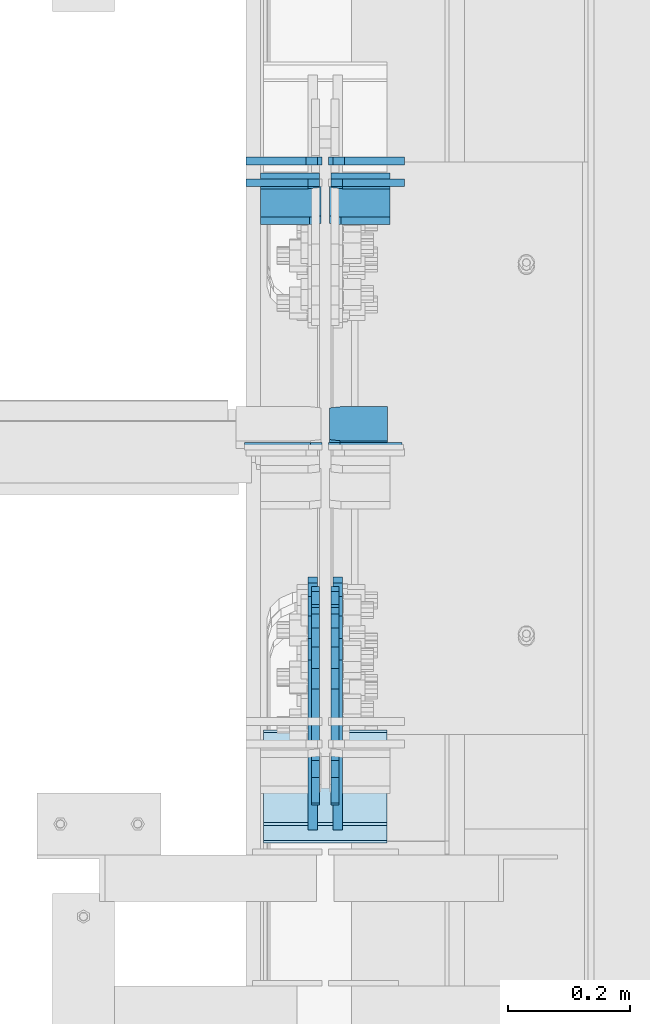
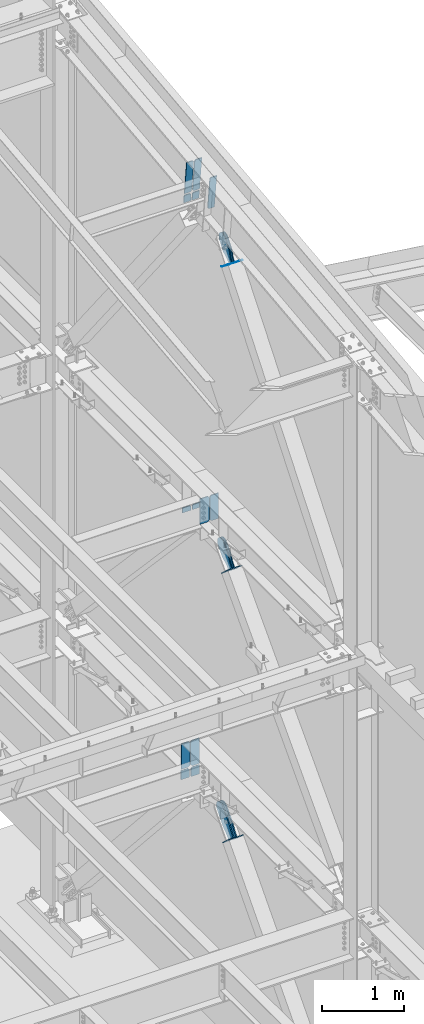
# One storey, part 1048 of 1179: 22 plates, 12 elements without a shape of their own.
"""IFC2X3 building model written with IfcOpenShell, lengths in millimetres."""

from ifc_helpers import new_model, si_unit, frame, origin_with_axes, place, context, subcontext, project, spatial, faceted_brep, material, type_object, element, aggregate, save


model = new_model("IFC2X3")

# Units and contexts
model_context = context("Model", 3, precision=1e-05, world=origin_with_axes())
body_context = subcontext(model_context, "Body", "Model", "MODEL_VIEW")
ifc_project = project(units=[si_unit("LENGTHUNIT", "METRE", prefix="MILLI"), si_unit("AREAUNIT", "SQUARE_METRE"), si_unit("VOLUMEUNIT", "CUBIC_METRE"), si_unit("MASSUNIT", "GRAM", prefix="KILO"), si_unit("TIMEUNIT", "SECOND"), si_unit("PLANEANGLEUNIT", "RADIAN"), si_unit("SOLIDANGLEUNIT", "STERADIAN"), si_unit("THERMODYNAMICTEMPERATUREUNIT", "DEGREE_CELSIUS"), si_unit("LUMINOUSINTENSITYUNIT", "LUMEN")], contexts=[model_context])

# Site, building, storey
site_placement = place(None, origin_with_axes())
site = spatial("IfcSite", under=ifc_project, at=site_placement, CompositionType="ELEMENT")
building_placement = place(site_placement, origin_with_axes())
building = spatial("IfcBuilding", under=site, at=building_placement, Name="Undefined", CompositionType="ELEMENT")
storey_placement = place(building_placement, origin_with_axes())
storey = spatial("IfcBuildingStorey", under=building, at=storey_placement, Name="Undefined", CompositionType="ELEMENT", Elevation=0.0)

# Assembly, plates
assembly_1_placement = place(storey_placement, origin_with_axes())
assembly_1 = element("IfcElementAssembly", 1, at=assembly_1_placement, inside=storey, Name="BEAM", AssemblyPlace="NOTDEFINED", PredefinedType="RIGID_FRAME")
ifc_material_1 = material(Name="STEEL/A36")
plate_type_1 = type_object("IfcPlateType", PredefinedType="NOTDEFINED")
plate_1_placement = place(assembly_1_placement, frame((24314.94375, 30789.5969267613, 12198.8547612226), z_axis=(0.0, -0.112284087038017, 0.993676146336441), x_axis=(1.0, 0.0, 0.0)))
plate_1 = element("IfcPlate", 2, at=plate_1_placement, type_object=plate_type_1, material=ifc_material_1, Name="PLATE", context=body_context, shape_type="Brep", body=[
    faceted_brep([(0.0, -6.34999999998763, 17.4624996185248), (0.0, -6.34999999979846, 481.012500380079), (0.0, 6.350000000195, 481.012500380073), (0.0, 6.35000000000582, 17.4624996185175), (17.4624996185303, -6.349999999793, 498.474999998598), (17.4624996185303, 6.35000000020045, 498.474999998592), (95.25, -6.349999999793, 498.474999998598), (95.25, 6.35000000020045, 498.474999998592), (95.25, -6.34999999999309, 1.81898940354586e-12), (95.25, 6.34999999999854, -1.81898940354586e-12), (17.4624996185303, -6.34999999999309, 1.81898940354586e-12), (17.4624996185303, 6.34999999999854, -1.81898940354586e-12)], [[[0, 1, 2, 3]], [[1, 4, 5, 2]], [[4, 6, 7, 5]], [[6, 8, 9, 7]], [[8, 10, 11, 9]], [[10, 0, 3, 11]], [[5, 7, 9, 11, 3, 2]], [[10, 8, 6, 4, 1, 0]]]),
])
ifc_material_2 = material(Name="STEEL/A572-GR.50")
plate_type_2 = type_object("IfcPlateType", PredefinedType="NOTDEFINED")
plate_2_placement = place(assembly_1_placement, frame((24414.1625, 31157.0572320607, 12240.377288512), z_axis=(0.0, -0.112284087038017, 0.993676146336441), x_axis=(-1.0, 0.0, 0.0)))
plate_2 = element("IfcPlate", 3, at=plate_2_placement, type_object=plate_type_2, material=ifc_material_2, Name="PLATE", context=body_context, shape_type="Brep", body=[
    faceted_brep([(0.0, -6.34999999999854, 0.0), (0.0, -6.35000000019863, 498.474999998592), (0.0, 6.34999999979118, 498.474999998596), (0.0, 6.34999999999854, 0.0), (80.1687507629395, -6.35000000020227, 498.474999998592), (80.1687507629395, 6.34999999978754, 498.474999998596), (99.21875, -6.350000000195, 479.425000761543), (99.21875, 6.34999999980209, 479.425000761548), (99.21875, -6.35000000000946, 19.0499992370478), (99.21875, 6.34999999998399, 19.0499992370533), (80.1687507629395, -6.35000000000218, 0.0), (80.1687507629395, 6.34999999999491, 3.63797880709171e-12)], [[[0, 1, 2, 3]], [[1, 4, 5, 2]], [[4, 6, 7, 5]], [[6, 8, 9, 7]], [[8, 10, 11, 9]], [[10, 0, 3, 11]], [[5, 7, 9, 11, 3, 2]], [[10, 8, 6, 4, 1, 0]]]),
])
plate_3_placement = place(assembly_1_placement, frame((24300.65625, 31157.0572320607, 12240.377288512), z_axis=(0.0, -0.112284087038017, 0.993676146336441), x_axis=(-1.0, 0.0, 0.0)))
plate_3 = element("IfcPlate", 4, at=plate_3_placement, type_object=plate_type_2, material=ifc_material_2, Name="PLATE", context=body_context, shape_type="Brep", body=[
    faceted_brep([(0.0, -6.35000000000036, 19.0499999999993), (0.0, -6.350000000195, 479.425000761541), (0.0, 6.34999999980209, 479.425000761548), (0.0, 6.35000000000036, 19.0499999999993), (19.0499992370605, -6.35000000019863, 498.474999998592), (19.0499992370605, 6.34999999979118, 498.474999998596), (99.21875, -6.35000000020227, 498.474999998592), (99.21875, 6.34999999978754, 498.474999998596), (99.21875, -6.35000000000218, 0.0), (99.21875, 6.34999999999491, 3.63797880709171e-12), (19.0500000000002, -6.35000000000036, 0.0), (19.0500000000002, 6.35000000000036, 0.0)], [[[0, 1, 2, 3]], [[1, 4, 5, 2]], [[4, 6, 7, 5]], [[6, 8, 9, 7]], [[8, 10, 11, 9]], [[3, 11, 10, 0]], [[5, 7, 9, 11, 3, 2]], [[10, 8, 6, 4, 1, 0]]]),
])

# Assembly, plate
assembly_2_placement = place(storey_placement, origin_with_axes())
assembly_2 = element("IfcElementAssembly", 5, at=assembly_2_placement, inside=storey, Name="BEAM", AssemblyPlace="NOTDEFINED", PredefinedType="RIGID_FRAME")
plate_type_3 = type_object("IfcPlateType", PredefinedType="NOTDEFINED")
plate_4_placement = place(assembly_2_placement, frame((24313.35625, 31199.2949954247, 3703.6375), z_axis=(0.0, 0.0, 1.0), x_axis=(1.0, 0.0, 0.0)))
plate_4 = element("IfcPlate", 6, at=plate_4_placement, type_object=plate_type_3, material=ifc_material_2, Name="PLATE", context=body_context, shape_type="Brep", body=[
    faceted_brep([(0.0, -6.34999999999854, 22.2250003814697), (0.0, -6.34999999999854, 355.600011825562), (0.0, 6.34999999999854, 355.600011825562), (0.0, 6.34999999999854, 22.2250003814697), (22.2250003814697, -6.34999999999854, 377.825012207031), (22.2250003814697, 6.34999999999854, 377.825012207031), (120.650001525879, -6.34999999999854, 377.825012207031), (120.650001525879, 6.34999999999854, 377.825012207031), (120.650001525879, -6.34999999999854, 0.0), (120.650001525879, 6.34999999999854, 0.0), (22.2250003814697, -6.34999999999854, 0.0), (22.2250003814697, 6.34999999999854, 0.0)], [[[0, 1, 2, 3]], [[1, 4, 5, 2]], [[4, 6, 7, 5]], [[6, 8, 9, 7]], [[8, 10, 11, 9]], [[10, 0, 3, 11]], [[5, 7, 9, 11, 3, 2]], [[10, 8, 6, 4, 1, 0]]]),
])

assembly_3_placement = place(storey_placement, origin_with_axes())
assembly_3 = element("IfcElementAssembly", 7, at=assembly_3_placement, inside=storey, Name="BEAM", AssemblyPlace="NOTDEFINED", PredefinedType="RIGID_FRAME")
plate_5_placement = place(assembly_3_placement, frame((24313.35625, 30730.825, 7615.2375), z_axis=(0.0, 0.0, 1.0), x_axis=(1.0, 0.0, 0.0)))
plate_5 = element("IfcPlate", 8, at=plate_5_placement, type_object=plate_type_3, material=ifc_material_2, Name="PLATE", context=body_context, shape_type="Brep", body=[
    faceted_brep([(0.0, -6.35000000000036, 19.0499999999993), (0.0, -6.34999999999854, 358.775000762939), (0.0, 6.34999999999854, 358.775000762939), (0.0, 6.35000000000036, 19.0499999999993), (19.0499992370605, -6.34999999999854, 377.825), (19.0499992370605, 6.34999999999854, 377.825), (120.650001525879, -6.34999999999854, 377.825012207031), (120.650001525879, 6.34999999999854, 377.825012207031), (120.650001525879, -6.34999999999854, 0.0), (120.650001525879, 6.34999999999854, 0.0), (19.0500000000002, -6.35000000000036, 0.0), (19.0500000000002, 6.35000000000036, 0.0)], [[[0, 1, 2, 3]], [[1, 4, 5, 2]], [[4, 6, 7, 5]], [[6, 8, 9, 7]], [[8, 10, 11, 9]], [[3, 11, 10, 0]], [[5, 7, 9, 11, 3, 2]], [[10, 8, 6, 4, 1, 0]]]),
])

# Plate
plate_6_placement = place(assembly_2_placement, frame((24302.24375, 31199.2949954247, 3703.6375), z_axis=(0.0, 0.0, 1.0), x_axis=(-1.0, 0.0, 0.0)))
plate_6 = element("IfcPlate", 9, at=plate_6_placement, type_object=plate_type_3, material=ifc_material_2, Name="PLATE", context=body_context, shape_type="Brep", body=[
    faceted_brep([(0.0, -6.34999999999854, 22.2250003814697), (0.0, -6.34999999999854, 355.600011825562), (0.0, 6.34999999999854, 355.600011825562), (0.0, 6.34999999999854, 22.2250003814697), (22.2250003814697, -6.34999999999854, 377.825012207031), (22.2250003814697, 6.34999999999854, 377.825012207031), (120.650001525879, -6.34999999999854, 377.825012207031), (120.650001525879, 6.34999999999854, 377.825012207031), (120.650001525879, -6.34999999999854, 0.0), (120.650001525879, 6.34999999999854, 0.0), (22.2250003814697, -6.34999999999854, 0.0), (22.2250003814697, 6.34999999999854, 0.0)], [[[0, 1, 2, 3]], [[1, 4, 5, 2]], [[4, 6, 7, 5]], [[6, 8, 9, 7]], [[8, 10, 11, 9]], [[10, 0, 3, 11]], [[5, 7, 9, 11, 3, 2]], [[10, 8, 6, 4, 1, 0]]]),
])

# Assembly, plate
assembly_4_placement = place(storey_placement, origin_with_axes())
assembly_4 = element("IfcElementAssembly", 10, at=assembly_4_placement, inside=storey, AssemblyPlace="NOTDEFINED", PredefinedType="RIGID_FRAME")
plate_type_4 = type_object("IfcPlateType", PredefinedType="NOTDEFINED")
plate_7_placement = place(assembly_4_placement, frame((24291.925, 30217.3266716375, 11731.3433869439), z_axis=(0.0, -0.784153429306141, 0.620566998242268), x_axis=(0.0, 0.62056699824227, 0.78415342930614)))
plate_7 = element("IfcPlate", 11, at=plate_7_placement, type_object=plate_type_4, material=ifc_material_1, context=body_context, shape_type="Brep", body=[
    faceted_brep([(0.0, -6.34999999999854, 0.0), (-8.18545231595635e-11, -6.34999999999854, 91.5986124346418), (-8.18545231595635e-11, 6.34999999999854, 91.5986124346418), (0.0, 6.34999999999854, 0.0), (67.3100000000013, -6.35000000000002, 91.5986124352912), (67.3100000000013, 6.35000000000002, 91.5986124352912), (168.909999999782, -6.35000000000002, 136.286806218), (168.909999999782, 6.35000000000002, 136.286806218), (313.994985846162, -6.35000000000002, 136.286806217971), (313.994985846162, 6.35000000000002, 136.286806217971), (348.623054100175, -6.35000000000002, 129.398855183776), (348.623054100175, 6.35000000000002, 129.398855183776), (377.979312866712, -6.35000000000002, 109.783630186734), (377.979312866712, 6.35000000000002, 109.783630186734), (397.594537863708, -6.35000000000002, 80.4273714201881), (397.594537863708, 6.35000000000002, 80.4273714201881), (404.482488897822, -6.35000000000002, 45.7993092687429), (404.482488897822, 6.35000000000002, 45.7993092687429), (397.594537863562, -6.35000000000002, 11.1712410148175), (397.594537863562, 6.35000000000002, 11.1712410148175), (377.979312866471, -6.35000000000002, -18.1850177516571), (377.979312866471, 6.35000000000002, -18.1850177516571), (348.623054099906, -6.35000000000002, -37.800242748639), (348.623054099906, 6.35000000000002, -37.800242748639), (313.994988897899, -6.35000000000002, -44.6881937828002), (313.994988897899, 6.35000000000002, -44.6881937828002), (168.909999999352, -6.35000000000002, -44.6881937827711), (168.909999999352, 6.35000000000002, -44.6881937827711), (67.309999999783, -6.35000000000002, -1.09139364212751e-11), (67.309999999783, 6.35000000000002, -1.09139364212751e-11)], [[[0, 1, 2, 3]], [[1, 4, 5, 2]], [[4, 6, 7, 5]], [[6, 8, 9, 7]], [[8, 10, 11, 9]], [[10, 12, 13, 11]], [[12, 14, 15, 13]], [[14, 16, 17, 15]], [[16, 18, 19, 17]], [[18, 20, 21, 19]], [[20, 22, 23, 21]], [[22, 24, 25, 23]], [[24, 26, 27, 25]], [[26, 28, 29, 27]], [[28, 0, 3, 29]], [[5, 7, 9, 11, 13, 15, 17, 19, 21, 23, 25, 27, 29, 3, 2]], [[28, 26, 24, 22, 20, 18, 16, 14, 12, 10, 8, 6, 4, 1, 0]]]),
])
aggregate(assembly_4, [plate_7])

assembly_5_placement = place(storey_placement, origin_with_axes())
assembly_5 = element("IfcElementAssembly", 12, at=assembly_5_placement, inside=storey, AssemblyPlace="NOTDEFINED", PredefinedType="RIGID_FRAME")
plate_8_placement = place(assembly_5_placement, frame((24323.675, 30217.3266716375, 11731.3433869439), z_axis=(0.0, -0.784153429306141, 0.620566998242268), x_axis=(0.0, 0.62056699824227, 0.78415342930614)))
plate_8 = element("IfcPlate", 13, at=plate_8_placement, type_object=plate_type_4, material=ifc_material_1, context=body_context, shape_type="Brep", body=[
    faceted_brep([(0.0, -6.34999999999854, 0.0), (-8.18545231595635e-11, -6.34999999999854, 91.5986124346418), (-8.18545231595635e-11, 6.34999999999854, 91.5986124346418), (0.0, 6.34999999999854, 0.0), (67.3100000000013, -6.35000000000002, 91.5986124352912), (67.3100000000013, 6.35000000000002, 91.5986124352912), (168.909999999782, -6.35000000000002, 136.286806218), (168.909999999782, 6.35000000000002, 136.286806218), (313.994985846162, -6.35000000000002, 136.286806217971), (313.994985846162, 6.35000000000002, 136.286806217971), (348.623054100175, -6.35000000000002, 129.398855183776), (348.623054100175, 6.35000000000002, 129.398855183776), (377.979312866712, -6.35000000000002, 109.783630186734), (377.979312866712, 6.35000000000002, 109.783630186734), (397.594537863708, -6.35000000000002, 80.4273714201881), (397.594537863708, 6.35000000000002, 80.4273714201881), (404.482488897822, -6.35000000000002, 45.7993092687429), (404.482488897822, 6.35000000000002, 45.7993092687429), (397.594537863562, -6.35000000000002, 11.1712410148175), (397.594537863562, 6.35000000000002, 11.1712410148175), (377.979312866471, -6.35000000000002, -18.1850177516571), (377.979312866471, 6.35000000000002, -18.1850177516571), (348.623054099906, -6.35000000000002, -37.800242748639), (348.623054099906, 6.35000000000002, -37.800242748639), (313.994988897899, -6.35000000000002, -44.6881937828002), (313.994988897899, 6.35000000000002, -44.6881937828002), (168.909999999352, -6.35000000000002, -44.6881937827711), (168.909999999352, 6.35000000000002, -44.6881937827711), (67.309999999783, -6.35000000000002, -1.09139364212751e-11), (67.309999999783, 6.35000000000002, -1.09139364212751e-11)], [[[0, 1, 2, 3]], [[1, 4, 5, 2]], [[4, 6, 7, 5]], [[6, 8, 9, 7]], [[8, 10, 11, 9]], [[10, 12, 13, 11]], [[12, 14, 15, 13]], [[14, 16, 17, 15]], [[16, 18, 19, 17]], [[18, 20, 21, 19]], [[20, 22, 23, 21]], [[22, 24, 25, 23]], [[24, 26, 27, 25]], [[26, 28, 29, 27]], [[28, 0, 3, 29]], [[5, 7, 9, 11, 13, 15, 17, 19, 21, 23, 25, 27, 29, 3, 2]], [[28, 26, 24, 22, 20, 18, 16, 14, 12, 10, 8, 6, 4, 1, 0]]]),
])
aggregate(assembly_5, [plate_8])

assembly_6_placement = place(storey_placement, origin_with_axes())
assembly_6 = element("IfcElementAssembly", 14, at=assembly_6_placement, inside=storey, Name="Plate", AssemblyPlace="NOTDEFINED", PredefinedType="RIGID_FRAME")
plate_type_5 = type_object("IfcPlateType", PredefinedType="NOTDEFINED")
plate_9_placement = place(assembly_6_placement, frame((24409.4, 30263.0532772467, 11699.2050050436), z_axis=(0.0, -0.784153429306141, 0.620566998242268), x_axis=(-1.0, 0.0, 0.0)))
plate_9 = element("IfcPlate", 15, at=plate_9_placement, type_object=plate_type_5, material=ifc_material_1, Name="Plate", context=body_context, shape_type="Brep", body=[
    faceted_brep([(0.0, -3.17500000000109, 0.0), (0.0, -3.17500000000291, 203.200000000368), (0.0, 3.17499999998836, 203.200000000361), (0.0, 3.17500000000109, 7.27595761418343e-12), (203.199999999997, -3.17500000000291, 203.200000000368), (203.199999999997, 3.17499999998836, 203.200000000361), (203.199999999997, -3.17499999999927, 3.63797880709171e-12), (203.199999999997, 3.17499999999382, -3.63797880709171e-12)], [[[0, 1, 2, 3]], [[1, 4, 5, 2]], [[4, 6, 7, 5]], [[6, 0, 3, 7]], [[5, 7, 3, 2]], [[6, 4, 1, 0]]]),
])
aggregate(assembly_6, [plate_9])

assembly_7_placement = place(storey_placement, origin_with_axes())
assembly_7 = element("IfcElementAssembly", 16, at=assembly_7_placement, inside=storey, Name="Plate", AssemblyPlace="NOTDEFINED", PredefinedType="RIGID_FRAME")
plate_10_placement = place(assembly_7_placement, frame((24409.4, 30258.8835102987, 7162.85000800912), z_axis=(0.0, -0.729241792887682, 0.684256097894611), x_axis=(-1.0, 0.0, 0.0)))
plate_10 = element("IfcPlate", 17, at=plate_10_placement, type_object=plate_type_5, material=ifc_material_1, Name="Plate", context=body_context, shape_type="Brep", body=[
    faceted_brep([(0.0, -3.17500000000109, 0.0), (0.0, -3.17500000000291, 203.200000000368), (0.0, 3.17499999998836, 203.200000000361), (0.0, 3.17500000000109, 7.27595761418343e-12), (203.199999999997, -3.17500000000291, 203.200000000368), (203.199999999997, 3.17499999998836, 203.200000000361), (203.199999999997, -3.17499999999927, 3.63797880709171e-12), (203.199999999997, 3.17499999999382, -3.63797880709171e-12)], [[[0, 1, 2, 3]], [[1, 4, 5, 2]], [[4, 6, 7, 5]], [[6, 0, 3, 7]], [[5, 7, 3, 2]], [[6, 4, 1, 0]]]),
])
aggregate(assembly_7, [plate_10])

assembly_8_placement = place(storey_placement, origin_with_axes())
assembly_8 = element("IfcElementAssembly", 18, at=assembly_8_placement, inside=storey, Name="Plate", AssemblyPlace="NOTDEFINED", PredefinedType="RIGID_FRAME")
plate_11_placement = place(assembly_8_placement, frame((24409.4, 30233.4403584389, 3193.9493141799), z_axis=(0.0, -0.74575357167811, 0.666221892712438), x_axis=(-1.0, 0.0, 0.0)))
plate_11 = element("IfcPlate", 19, at=plate_11_placement, type_object=plate_type_5, material=ifc_material_1, Name="Plate", context=body_context, shape_type="Brep", body=[
    faceted_brep([(0.0, -3.17500000000109, 0.0), (0.0, -3.17500000000291, 203.200000000368), (0.0, 3.17499999998836, 203.200000000361), (0.0, 3.17500000000109, 7.27595761418343e-12), (203.199999999997, -3.17500000000291, 203.200000000368), (203.199999999997, 3.17499999998836, 203.200000000361), (203.199999999997, -3.17499999999927, 3.63797880709171e-12), (203.199999999997, 3.17499999999382, -3.63797880709171e-12)], [[[0, 1, 2, 3]], [[1, 4, 5, 2]], [[4, 6, 7, 5]], [[6, 0, 3, 7]], [[5, 7, 3, 2]], [[6, 4, 1, 0]]]),
])
aggregate(assembly_8, [plate_11])

# Plate
plate_type_6 = type_object("IfcPlateType", PredefinedType="NOTDEFINED")
plate_12_placement = place(assembly_1_placement, frame((24298.275, 31159.909247798, 12215.1379150462), z_axis=(-1.0, 0.0, 0.0), x_axis=(0.0, 0.112284087038014, -0.993676146336441)))
plate_12 = element("IfcPlate", 20, at=plate_12_placement, type_object=plate_type_6, material=ifc_material_2, Name="PLATE", context=body_context, shape_type="Brep", body=[
    faceted_brep([(0.0, 6.35000000000036, 19.0499999999993), (19.0500000000002, 6.35000000000036, 0.0), (19.0500000000002, -6.35000000000036, 0.0), (0.0, -6.35000000000036, 19.0499999999993), (0.0, -6.35000000000036, 96.8374999999978), (0.0, 6.35000000000036, 96.8374999999978), (118.580622349293, -6.34999999995489, 96.8374999999978), (118.580622349285, 6.35000000003856, 96.8374999999978), (118.580622349293, -6.34999999995489, 0.0), (118.580622349285, 6.35000000003856, 0.0)], [[[0, 1, 2, 3]], [[4, 5, 0, 3]], [[4, 6, 7, 5]], [[6, 8, 9, 7]], [[9, 8, 2, 1]], [[5, 7, 9, 1, 0]], [[8, 6, 4, 3, 2]]]),
])

plate_13_placement = place(assembly_1_placement, frame((24317.325, 31159.909247798, 12215.1379150462), z_axis=(1.0, 0.0, 0.0), x_axis=(0.0, 0.112284087038014, -0.993676146336441)))
plate_13 = element("IfcPlate", 21, at=plate_13_placement, type_object=plate_type_6, material=ifc_material_2, Name="PLATE", context=body_context, shape_type="Brep", body=[
    faceted_brep([(0.0, 6.35000000000036, 19.0499999999993), (19.0500000000002, 6.35000000000036, 0.0), (19.0500000000002, -6.35000000000036, 0.0), (0.0, -6.35000000000036, 19.0499999999993), (0.0, -6.35000000000036, 96.8374999999978), (0.0, 6.35000000000036, 96.8374999999978), (118.580622349293, -6.34999999995489, 96.8374999999978), (118.580622349285, 6.35000000003856, 96.8374999999978), (118.580622349293, -6.34999999995489, 0.0), (118.580622349285, 6.35000000003856, 0.0)], [[[0, 1, 2, 3]], [[4, 5, 0, 3]], [[4, 6, 7, 5]], [[6, 8, 9, 7]], [[9, 8, 2, 1]], [[5, 7, 9, 1, 0]], [[8, 6, 4, 3, 2]]]),
])

aggregate(assembly_1, [plate_1, plate_2, plate_3, plate_12, plate_13])

plate_type_7 = type_object("IfcPlateType", PredefinedType="NOTDEFINED")
plate_14_placement = place(assembly_3_placement, frame((24302.24375, 30730.825, 7615.2375), z_axis=(0.0, 0.0, 1.0), x_axis=(-1.0, 0.0, 0.0)))
plate_14 = element("IfcPlate", 22, at=plate_14_placement, type_object=plate_type_7, material=ifc_material_2, Name="PLATE", context=body_context, shape_type="Brep", body=[
    faceted_brep([(0.0, -6.35000000000036, 19.0499999999993), (0.0, -6.34999999999854, 358.775000762939), (0.0, 6.34999999999854, 358.775000762939), (0.0, 6.35000000000036, 19.0499999999993), (19.0499992370605, -6.34999999999854, 377.825), (19.0499992370605, 6.34999999999854, 377.825), (127.000004873051, -6.34999999999854, 377.825), (127.000004873051, 6.34999999999854, 377.825), (127.000004873051, -6.34999999999854, 0.0), (127.000004873051, 6.34999999999854, 0.0), (19.0500000000002, -6.35000000000036, 0.0), (19.0500000000002, 6.35000000000036, 0.0)], [[[0, 1, 2, 3]], [[1, 4, 5, 2]], [[4, 6, 7, 5]], [[6, 8, 9, 7]], [[8, 10, 11, 9]], [[3, 11, 10, 0]], [[5, 7, 9, 11, 3, 2]], [[10, 8, 6, 4, 1, 0]]]),
])

plate_type_8 = type_object("IfcPlateType", PredefinedType="NOTDEFINED")
plate_15_placement = place(assembly_3_placement, frame((24298.275, 31163.6495595727, 7594.59999993917), z_axis=(-1.0, 0.0, 0.0), x_axis=(0.0, 0.0, -1.0)))
plate_15 = element("IfcPlate", 23, at=plate_15_placement, type_object=plate_type_8, material=ifc_material_2, Name="PLATE", context=body_context, shape_type="Brep", body=[
    faceted_brep([(0.0, 6.35000000000036, 19.0499999999993), (19.0500000000002, 6.35000000000036, 0.0), (19.0500000000002, -6.35000000000036, 0.0), (0.0, -6.35000000000036, 19.0499999999993), (0.0, -6.34999999999854, 120.650000000001), (0.0, 6.34999999999854, 120.650000000001), (73.0249999999996, -6.34999999999854, 120.650000000001), (73.0249999999996, 6.34999999999854, 120.650000000001), (73.0249999999996, -6.34999999999854, 0.0), (73.0249999999996, 6.34999999999854, 0.0)], [[[0, 1, 2, 3]], [[4, 5, 0, 3]], [[4, 6, 7, 5]], [[6, 8, 9, 7]], [[9, 8, 2, 1]], [[5, 7, 9, 1, 0]], [[8, 6, 4, 3, 2]]]),
])

plate_16_placement = place(assembly_3_placement, frame((24317.325, 31163.6495595727, 7594.59999993917), z_axis=(1.0, 0.0, 0.0), x_axis=(0.0, 0.0, -1.0)))
plate_16 = element("IfcPlate", 24, at=plate_16_placement, type_object=plate_type_8, material=ifc_material_2, Name="PLATE", context=body_context, shape_type="Brep", body=[
    faceted_brep([(0.0, 6.35000000000036, 19.0499999999993), (19.0500000000002, 6.35000000000036, 0.0), (19.0500000000002, -6.35000000000036, 0.0), (0.0, -6.35000000000036, 19.0499999999993), (0.0, -6.34999999999854, 120.650000000001), (0.0, 6.34999999999854, 120.650000000001), (73.0249999999996, -6.34999999999854, 120.650000000001), (73.0249999999996, 6.34999999999854, 120.650000000001), (73.0249999999996, -6.34999999999854, 0.0), (73.0249999999996, 6.34999999999854, 0.0)], [[[0, 1, 2, 3]], [[4, 5, 0, 3]], [[4, 6, 7, 5]], [[6, 8, 9, 7]], [[9, 8, 2, 1]], [[5, 7, 9, 1, 0]], [[8, 6, 4, 3, 2]]]),
])

aggregate(assembly_3, [plate_5, plate_14, plate_15, plate_16])

plate_type_9 = type_object("IfcPlateType", PredefinedType="NOTDEFINED")
plate_17_placement = place(assembly_2_placement, frame((24295.1, 31199.2949948894, 3549.22923393386), z_axis=(-1.0, 0.0, 0.0), x_axis=(0.0, 0.0, 1.0)))
plate_17 = element("IfcPlate", 25, at=plate_17_placement, type_object=plate_type_9, material=ifc_material_2, Name="PLATE", context=body_context, shape_type="Brep", body=[
    faceted_brep([(0.0, -6.34999999999854, 0.0), (0.0, -6.35000000000036, 117.474999999999), (0.0, 6.35000000000036, 117.474999999999), (0.0, 6.34999999999854, 0.0), (133.770766104238, -6.34999999976571, 117.475000000002), (133.770766104239, 6.35000000023501, 117.475000000002), (133.770766104238, -6.34999999976571, 19.0499992370605), (133.770766104239, 6.35000000023501, 19.0499992370605), (114.720766867178, -6.34999999979846, 0.0), (114.720766867178, 6.35000000020227, 0.0)], [[[0, 1, 2, 3]], [[1, 4, 5, 2]], [[4, 6, 7, 5]], [[6, 8, 9, 7]], [[8, 0, 3, 9]], [[5, 7, 9, 3, 2]], [[8, 6, 4, 1, 0]]]),
])

plate_18_placement = place(assembly_2_placement, frame((24320.5, 31199.2949948894, 3549.22923393386), z_axis=(1.0, 0.0, 0.0), x_axis=(0.0, 0.0, 1.0)))
plate_18 = element("IfcPlate", 26, at=plate_18_placement, type_object=plate_type_9, material=ifc_material_2, Name="PLATE", context=body_context, shape_type="Brep", body=[
    faceted_brep([(0.0, -6.34999999999854, 0.0), (0.0, -6.35000000000036, 117.474999999999), (0.0, 6.35000000000036, 117.474999999999), (0.0, 6.34999999999854, 0.0), (133.770766104238, -6.34999999976571, 117.475000000002), (133.770766104239, 6.35000000023501, 117.475000000002), (133.770766104238, -6.34999999976571, 19.0499992370605), (133.770766104239, 6.35000000023501, 19.0499992370605), (114.720766867178, -6.34999999979846, 0.0), (114.720766867178, 6.35000000020227, 0.0)], [[[0, 1, 2, 3]], [[1, 4, 5, 2]], [[4, 6, 7, 5]], [[6, 8, 9, 7]], [[8, 0, 3, 9]], [[5, 7, 9, 3, 2]], [[8, 6, 4, 1, 0]]]),
])

aggregate(assembly_2, [plate_4, plate_6, plate_17, plate_18])

# Assembly, plate
assembly_9_placement = place(storey_placement, origin_with_axes())
assembly_9 = element("IfcElementAssembly", 27, at=assembly_9_placement, inside=storey, AssemblyPlace="NOTDEFINED", PredefinedType="RIGID_FRAME")
plate_type_10 = type_object("IfcPlateType", PredefinedType="NOTDEFINED")
plate_19_placement = place(assembly_9_placement, frame((24291.925, 30223.5250010686, 7191.67347336481), z_axis=(0.0, -0.729241792887682, 0.684256097894611), x_axis=(0.0, 0.684256097894612, 0.729241792887681)))
plate_19 = element("IfcPlate", 28, at=plate_19_placement, type_object=plate_type_10, material=ifc_material_1, context=body_context, shape_type="Brep", body=[
    faceted_brep([(0.0, -6.34999999999854, 0.0), (-4.35647962149233e-10, -6.34999999999854, 112.184930806416), (-4.35647962149233e-10, 6.34999999999854, 112.184930806416), (0.0, 6.34999999999854, 0.0), (82.5499999996491, -6.34999999999854, 112.184930806461), (82.5499999996491, 6.34999999999854, 112.184930806461), (184.149999999618, -6.34999999999854, 149.75496540347), (184.149999999618, 6.34999999999854, 149.75496540347), (327.919242323534, -6.34999999999854, 149.754965403559), (327.919242323534, 6.34999999999854, 149.754965403559), (363.762328723451, -6.34999999999854, 142.625332233587), (363.762328723451, 6.34999999999854, 142.625332233587), (394.148630137406, -6.34999999999854, 122.321854743475), (394.148630137406, 6.34999999999854, 122.321854743475), (414.452107627645, -6.34999999999854, 91.9355533295929), (414.452107627645, 6.34999999999854, 91.9355533295929), (421.581740797776, -6.34999999999854, 56.0924638777396), (421.581740797776, 6.34999999999854, 56.0924638777396), (414.452107627878, -6.34999999999854, 20.2493774776722), (414.452107627878, 6.34999999999854, 20.2493774776722), (394.14863013775, -6.34999999999854, -10.1369239363994), (394.14863013775, 6.34999999999854, -10.1369239363994), (363.762328723789, -6.34999999999854, -30.4404014266784), (363.762328723789, 6.34999999999854, -30.4404014266784), (327.919240798041, -6.34999999999854, -37.570034596738), (327.919240798041, 6.34999999999854, -37.570034596738), (184.150000000338, -6.34999999999854, -37.5700345968289), (184.150000000338, 6.34999999999854, -37.5700345968289), (82.550000000203, -6.34999999999854, 1.2732925824821e-10), (82.550000000203, 6.34999999999854, 1.2732925824821e-10)], [[[0, 1, 2, 3]], [[1, 4, 5, 2]], [[4, 6, 7, 5]], [[6, 8, 9, 7]], [[8, 10, 11, 9]], [[10, 12, 13, 11]], [[12, 14, 15, 13]], [[14, 16, 17, 15]], [[16, 18, 19, 17]], [[18, 20, 21, 19]], [[20, 22, 23, 21]], [[22, 24, 25, 23]], [[24, 26, 27, 25]], [[26, 28, 29, 27]], [[28, 0, 3, 29]], [[5, 7, 9, 11, 13, 15, 17, 19, 21, 23, 25, 27, 29, 3, 2]], [[28, 26, 24, 22, 20, 18, 16, 14, 12, 10, 8, 6, 4, 1, 0]]]),
])
aggregate(assembly_9, [plate_19])

assembly_10_placement = place(storey_placement, origin_with_axes())
assembly_10 = element("IfcElementAssembly", 29, at=assembly_10_placement, inside=storey, AssemblyPlace="NOTDEFINED", PredefinedType="RIGID_FRAME")
plate_20_placement = place(assembly_10_placement, frame((24323.675, 30223.5250010686, 7191.67347336481), z_axis=(0.0, -0.729241792887682, 0.684256097894611), x_axis=(0.0, 0.684256097894612, 0.729241792887681)))
plate_20 = element("IfcPlate", 30, at=plate_20_placement, type_object=plate_type_10, material=ifc_material_1, context=body_context, shape_type="Brep", body=[
    faceted_brep([(0.0, -6.34999999999854, 0.0), (-4.35647962149233e-10, -6.34999999999854, 112.184930806416), (-4.35647962149233e-10, 6.34999999999854, 112.184930806416), (0.0, 6.34999999999854, 0.0), (82.5499999996491, -6.34999999999854, 112.184930806461), (82.5499999996491, 6.34999999999854, 112.184930806461), (184.149999999618, -6.34999999999854, 149.75496540347), (184.149999999618, 6.34999999999854, 149.75496540347), (327.919242323534, -6.34999999999854, 149.754965403559), (327.919242323534, 6.34999999999854, 149.754965403559), (363.762328723451, -6.34999999999854, 142.625332233587), (363.762328723451, 6.34999999999854, 142.625332233587), (394.148630137406, -6.34999999999854, 122.321854743475), (394.148630137406, 6.34999999999854, 122.321854743475), (414.452107627645, -6.34999999999854, 91.9355533295929), (414.452107627645, 6.34999999999854, 91.9355533295929), (421.581740797776, -6.34999999999854, 56.0924638777396), (421.581740797776, 6.34999999999854, 56.0924638777396), (414.452107627878, -6.34999999999854, 20.2493774776722), (414.452107627878, 6.34999999999854, 20.2493774776722), (394.14863013775, -6.34999999999854, -10.1369239363994), (394.14863013775, 6.34999999999854, -10.1369239363994), (363.762328723789, -6.34999999999854, -30.4404014266784), (363.762328723789, 6.34999999999854, -30.4404014266784), (327.919240798041, -6.34999999999854, -37.570034596738), (327.919240798041, 6.34999999999854, -37.570034596738), (184.150000000338, -6.34999999999854, -37.5700345968289), (184.150000000338, 6.34999999999854, -37.5700345968289), (82.550000000203, -6.34999999999854, 1.2732925824821e-10), (82.550000000203, 6.34999999999854, 1.2732925824821e-10)], [[[0, 1, 2, 3]], [[1, 4, 5, 2]], [[4, 6, 7, 5]], [[6, 8, 9, 7]], [[8, 10, 11, 9]], [[10, 12, 13, 11]], [[12, 14, 15, 13]], [[14, 16, 17, 15]], [[16, 18, 19, 17]], [[18, 20, 21, 19]], [[20, 22, 23, 21]], [[22, 24, 25, 23]], [[24, 26, 27, 25]], [[26, 28, 29, 27]], [[28, 0, 3, 29]], [[5, 7, 9, 11, 13, 15, 17, 19, 21, 23, 25, 27, 29, 3, 2]], [[28, 26, 24, 22, 20, 18, 16, 14, 12, 10, 8, 6, 4, 1, 0]]]),
])
aggregate(assembly_10, [plate_20])

assembly_11_placement = place(storey_placement, origin_with_axes())
assembly_11 = element("IfcElementAssembly", 31, at=assembly_11_placement, inside=storey, AssemblyPlace="NOTDEFINED", PredefinedType="RIGID_FRAME")
plate_type_11 = type_object("IfcPlateType", PredefinedType="NOTDEFINED")
plate_21_placement = place(assembly_11_placement, frame((24287.1625, 30210.3339457257, 3210.33408050843), z_axis=(0.0, -0.74575357167811, 0.666221892712438), x_axis=(0.0, 0.666221892712437, 0.74575357167811)))
plate_21 = element("IfcPlate", 32, at=plate_21_placement, type_object=plate_type_11, material=ifc_material_1, context=body_context, shape_type="Brep", body=[
    faceted_brep([(0.0, -7.9375, 0.0), (-8.00355337560177e-11, -7.9375, 146.904840309817), (-8.00355337560177e-11, 7.9375, 146.904840309817), (0.0, 7.9375, 0.0), (77.4700000003613, -7.9375, 146.904840309813), (77.4700000003613, 7.9375, 146.904840309813), (179.070000002353, -7.9375, 168.702420152476), (179.070000002353, 7.9375, 168.702420152476), (398.391138856361, -7.9375, 168.70242015224), (398.391138856361, 7.9375, 168.70242015224), (434.841735789174, -7.9375, 161.451945623932), (434.841735789174, 7.9375, 161.451945623932), (465.743059764452, -7.9375, 140.804341060317), (465.743059764452, 7.9375, 140.804341060317), (486.390664328166, -7.9375, 109.903017085191), (486.390664328166, 7.9375, 109.903017085191), (493.641138856514, -7.9375, 73.4524201550448), (493.641138856514, 7.9375, 73.4524201550448), (486.390664328224, -7.9375, 37.0018232223083), (486.390664328224, 7.9375, 37.0018232223083), (465.743059764485, -7.9375, 6.10049924709892), (465.743059764485, 7.9375, 6.10049924709892), (434.841735789141, -7.9375, -14.5471053165493), (434.841735789141, 7.9375, -14.5471053165493), (398.39113885527, -7.9375, -21.7975798448133), (398.39113885527, 7.9375, -21.7975798448133), (179.070000002601, -7.9375, -21.7975798445805), (179.070000002601, 7.9375, -21.7975798445805), (77.4700000003904, -7.9375, -5.82076609134674e-11), (77.4700000003904, 7.9375, -5.82076609134674e-11)], [[[0, 1, 2, 3]], [[1, 4, 5, 2]], [[4, 6, 7, 5]], [[6, 8, 9, 7]], [[8, 10, 11, 9]], [[10, 12, 13, 11]], [[12, 14, 15, 13]], [[14, 16, 17, 15]], [[16, 18, 19, 17]], [[18, 20, 21, 19]], [[20, 22, 23, 21]], [[22, 24, 25, 23]], [[24, 26, 27, 25]], [[26, 28, 29, 27]], [[28, 0, 3, 29]], [[5, 7, 9, 11, 13, 15, 17, 19, 21, 23, 25, 27, 29, 3, 2]], [[28, 26, 24, 22, 20, 18, 16, 14, 12, 10, 8, 6, 4, 1, 0]]]),
])
aggregate(assembly_11, [plate_21])

assembly_12_placement = place(storey_placement, origin_with_axes())
assembly_12 = element("IfcElementAssembly", 33, at=assembly_12_placement, inside=storey, AssemblyPlace="NOTDEFINED", PredefinedType="RIGID_FRAME")
plate_22_placement = place(assembly_12_placement, frame((24328.4375, 30210.3339457257, 3210.33408050843), z_axis=(0.0, -0.74575357167811, 0.666221892712438), x_axis=(0.0, 0.666221892712437, 0.74575357167811)))
plate_22 = element("IfcPlate", 34, at=plate_22_placement, type_object=plate_type_11, material=ifc_material_1, context=body_context, shape_type="Brep", body=[
    faceted_brep([(0.0, -7.9375, 0.0), (-8.00355337560177e-11, -7.9375, 146.904840309817), (-8.00355337560177e-11, 7.9375, 146.904840309817), (0.0, 7.9375, 0.0), (77.4700000003613, -7.9375, 146.904840309813), (77.4700000003613, 7.9375, 146.904840309813), (179.070000002353, -7.9375, 168.702420152476), (179.070000002353, 7.9375, 168.702420152476), (398.391138856361, -7.9375, 168.70242015224), (398.391138856361, 7.9375, 168.70242015224), (434.841735789174, -7.9375, 161.451945623932), (434.841735789174, 7.9375, 161.451945623932), (465.743059764452, -7.9375, 140.804341060317), (465.743059764452, 7.9375, 140.804341060317), (486.390664328166, -7.9375, 109.903017085191), (486.390664328166, 7.9375, 109.903017085191), (493.641138856514, -7.9375, 73.4524201550448), (493.641138856514, 7.9375, 73.4524201550448), (486.390664328224, -7.9375, 37.0018232223083), (486.390664328224, 7.9375, 37.0018232223083), (465.743059764485, -7.9375, 6.10049924709892), (465.743059764485, 7.9375, 6.10049924709892), (434.841735789141, -7.9375, -14.5471053165493), (434.841735789141, 7.9375, -14.5471053165493), (398.39113885527, -7.9375, -21.7975798448133), (398.39113885527, 7.9375, -21.7975798448133), (179.070000002601, -7.9375, -21.7975798445805), (179.070000002601, 7.9375, -21.7975798445805), (77.4700000003904, -7.9375, -5.82076609134674e-11), (77.4700000003904, 7.9375, -5.82076609134674e-11)], [[[0, 1, 2, 3]], [[1, 4, 5, 2]], [[4, 6, 7, 5]], [[6, 8, 9, 7]], [[8, 10, 11, 9]], [[10, 12, 13, 11]], [[12, 14, 15, 13]], [[14, 16, 17, 15]], [[16, 18, 19, 17]], [[18, 20, 21, 19]], [[20, 22, 23, 21]], [[22, 24, 25, 23]], [[24, 26, 27, 25]], [[26, 28, 29, 27]], [[28, 0, 3, 29]], [[5, 7, 9, 11, 13, 15, 17, 19, 21, 23, 25, 27, 29, 3, 2]], [[28, 26, 24, 22, 20, 18, 16, 14, 12, 10, 8, 6, 4, 1, 0]]]),
])
aggregate(assembly_12, [plate_22])

save(model, "model.ifc")
